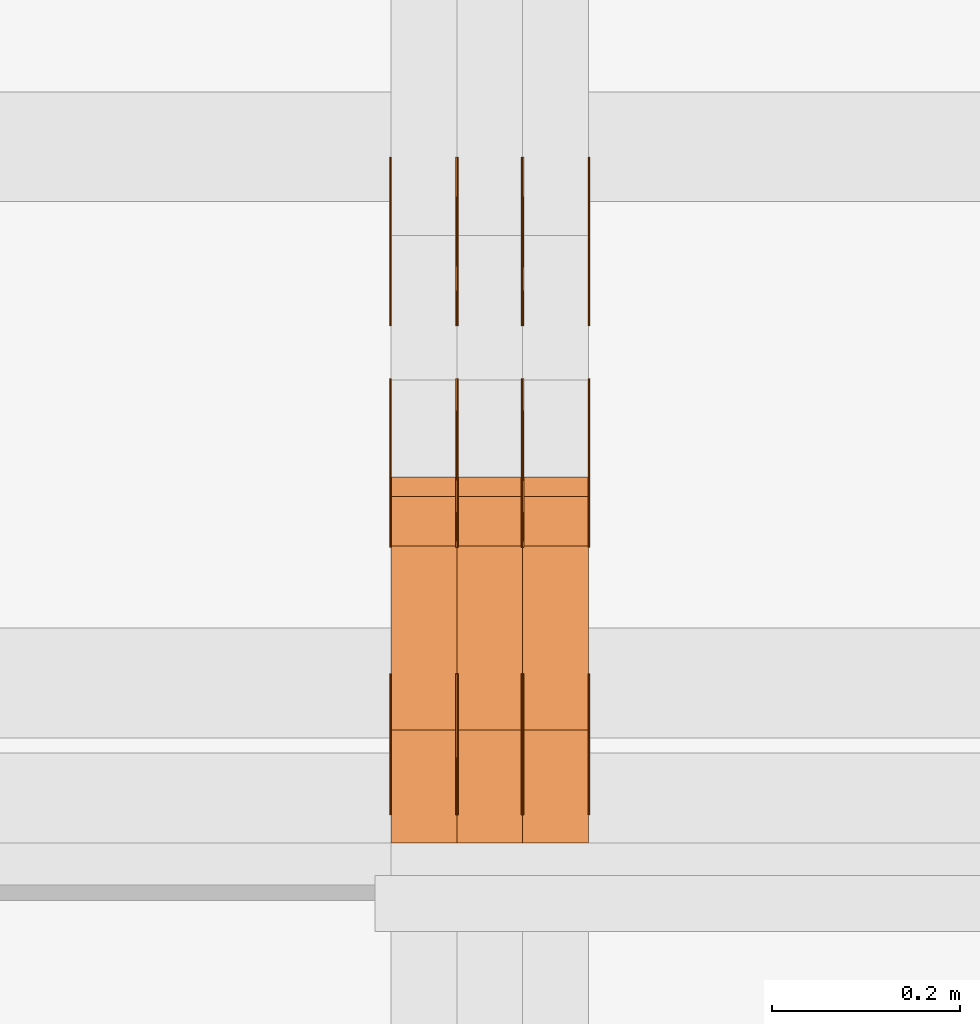
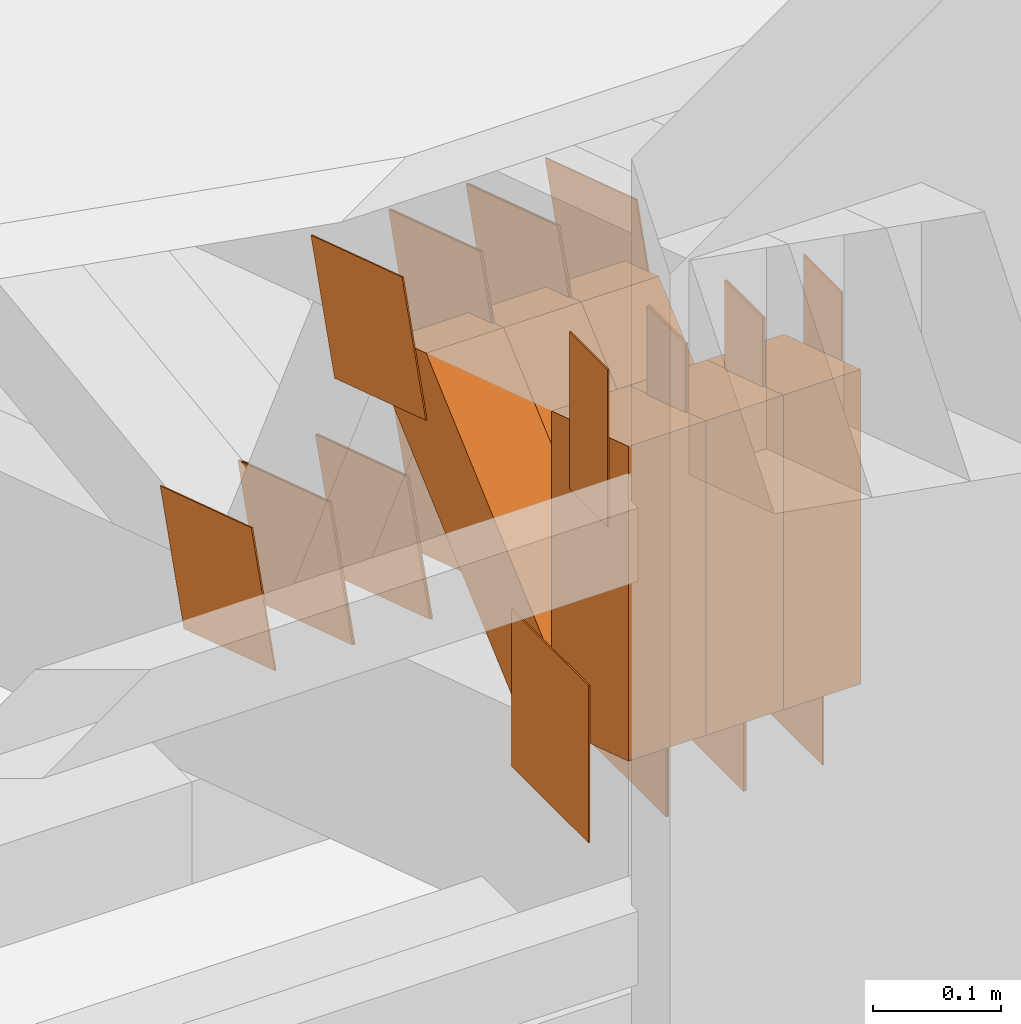
# One storey, part 99 of 385: 30 proxies.
"""IFC2X3 building model written with IfcOpenShell, lengths in millimetres."""

from ifc_helpers import new_model, entity, si_unit, converted_unit, derived_unit, direction, frame, origin, origin_2d_with_axis, place, context, subcontext, project, spatial, polyline, rectangle, outline, extrude, source, transform, mapped, material, type_object, type_shapes, element, save


model = new_model("IFC2X3")

# Units and contexts
model_context = context("Model", 3, precision=0.01, world=origin(), true_north=direction((6.12303176911189e-17, 1.0)))
body_context = subcontext(model_context, "Body", "Model", "MODEL_VIEW")
ifc_project = project(units=[si_unit("LENGTHUNIT", "METRE", prefix="MILLI"), si_unit("AREAUNIT", "SQUARE_METRE"), si_unit("VOLUMEUNIT", "CUBIC_METRE"), converted_unit("PLANEANGLEUNIT", "DEGREE", entity("IfcRatioMeasure", 0.0174532925199433), si_unit("PLANEANGLEUNIT", "RADIAN"), dimensions=[0, 0, 0, 0, 0, 0, 0]), si_unit("MASSUNIT", "GRAM", prefix="KILO"), derived_unit("MASSDENSITYUNIT", [(si_unit("MASSUNIT", "GRAM", prefix="KILO"), 1), (si_unit("LENGTHUNIT", "METRE"), -3)]), si_unit("TIMEUNIT", "SECOND"), si_unit("FREQUENCYUNIT", "HERTZ"), si_unit("THERMODYNAMICTEMPERATUREUNIT", "DEGREE_CELSIUS"), derived_unit("THERMALTRANSMITTANCEUNIT", [(si_unit("MASSUNIT", "GRAM", prefix="KILO"), 1), (si_unit("THERMODYNAMICTEMPERATUREUNIT", "KELVIN"), -1), (si_unit("TIMEUNIT", "SECOND"), -3)]), derived_unit("VOLUMETRICFLOWRATEUNIT", [(si_unit("LENGTHUNIT", "METRE"), 3), (si_unit("TIMEUNIT", "SECOND"), -1)]), si_unit("ELECTRICCURRENTUNIT", "AMPERE"), si_unit("ELECTRICVOLTAGEUNIT", "VOLT"), si_unit("POWERUNIT", "WATT"), si_unit("FORCEUNIT", "NEWTON", prefix="KILO"), si_unit("ILLUMINANCEUNIT", "LUX"), si_unit("LUMINOUSFLUXUNIT", "LUMEN"), si_unit("LUMINOUSINTENSITYUNIT", "CANDELA"), derived_unit("USERDEFINED", [(si_unit("MASSUNIT", "GRAM", prefix="KILO"), -1), (si_unit("LENGTHUNIT", "METRE"), -2), (si_unit("TIMEUNIT", "SECOND"), 3), (si_unit("LUMINOUSFLUXUNIT", "LUMEN"), 1)]), derived_unit("LINEARVELOCITYUNIT", [(si_unit("LENGTHUNIT", "METRE"), 1), (si_unit("TIMEUNIT", "SECOND"), -1)]), si_unit("PRESSUREUNIT", "PASCAL"), derived_unit("USERDEFINED", [(si_unit("LENGTHUNIT", "METRE"), -2), (si_unit("MASSUNIT", "GRAM", prefix="KILO"), 1), (si_unit("TIMEUNIT", "SECOND"), -2)])], contexts=[model_context])

# Site, building, storey
site_placement = place(None, origin())
site = spatial("IfcSite", under=ifc_project, at=site_placement, CompositionType="ELEMENT")
building_placement = place(site_placement, origin())
building = spatial("IfcBuilding", under=site, at=building_placement, CompositionType="ELEMENT")
storey_placement = place(building_placement, origin())
storey = spatial("IfcBuildingStorey", under=building, at=storey_placement, Name="Default", CompositionType="ELEMENT", Elevation=0.0)

# Proxies
ifc_material_1 = material(Name="IfcSurfaceStyle #136514")
building_element_proxy_type_1 = type_object("IfcBuildingElementProxyType", PredefinedType="NOTDEFINED", material=ifc_material_1)
shared_shape_1 = source(origin(), body_context, "Body", "SweptSolid", [
    extrude(rectangle(XDim=150.0, YDim=120.0, at=origin_2d_with_axis()), frame((75.0, 60.0, 0.0), z_axis=(0.0, 0.0, 1.0), x_axis=(-1.0, 0.0, 0.0)), (0.0, 0.0, 1.0), 1.3),
])
type_shapes(building_element_proxy_type_1, [shared_shape_1])
proxy_1_placement = place(building_placement, frame((9386.29999999998, 15840.0, 3652.70166015625), z_axis=(-1.0, 0.0, 0.0), x_axis=(0.0, 0.0, -1.0)))
element("IfcBuildingElementProxy", 1, at=proxy_1_placement, inside=storey, type_object=building_element_proxy_type_1, material=ifc_material_1, context=body_context, shape_type="MappedRepresentation", body=[
    mapped(shared_shape_1, transform((0.0, 0.0, 0.0), scale=1.0)),
])
ifc_material_2 = material(Name="IfcSurfaceStyle #136457")
building_element_proxy_type_2 = type_object("IfcBuildingElementProxyType", PredefinedType="NOTDEFINED", material=ifc_material_2)
shared_shape_2 = source(origin(), body_context, "Body", "SweptSolid", [
    extrude(rectangle(XDim=150.0, YDim=120.0, at=origin_2d_with_axis()), frame((75.0, 60.0, 0.0), z_axis=(0.0, 0.0, 1.0), x_axis=(-1.0, 0.0, 0.0)), (0.0, 0.0, 1.0), 1.3),
])
type_shapes(building_element_proxy_type_2, [shared_shape_2])
proxy_2_placement = place(building_placement, frame((9315.0, 15840.0, 3652.70166015625), z_axis=(-1.0, 0.0, 0.0), x_axis=(0.0, 0.0, -1.0)))
element("IfcBuildingElementProxy", 2, at=proxy_2_placement, inside=storey, type_object=building_element_proxy_type_2, material=ifc_material_2, context=body_context, shape_type="MappedRepresentation", body=[
    mapped(shared_shape_2, transform((0.0, 0.0, 0.0), scale=1.0)),
])
ifc_material_3 = material(Name="IfcSurfaceStyle #136400")
building_element_proxy_type_3 = type_object("IfcBuildingElementProxyType", PredefinedType="NOTDEFINED", material=ifc_material_3)
shared_shape_3 = source(origin(), body_context, "Body", "SweptSolid", [
    extrude(rectangle(XDim=150.0, YDim=120.0, at=origin_2d_with_axis()), frame((75.0, 60.0, 0.0), z_axis=(0.0, 0.0, 1.0), x_axis=(-1.0, 0.0, 0.0)), (0.0, 0.0, 1.0), 1.3),
])
type_shapes(building_element_proxy_type_3, [shared_shape_3])
proxy_3_placement = place(building_placement, frame((9316.29999999998, 15840.0, 3652.70166015625), z_axis=(-1.0, 0.0, 0.0), x_axis=(0.0, 0.0, -1.0)))
element("IfcBuildingElementProxy", 3, at=proxy_3_placement, inside=storey, type_object=building_element_proxy_type_3, material=ifc_material_3, context=body_context, shape_type="MappedRepresentation", body=[
    mapped(shared_shape_3, transform((0.0, 0.0, 0.0), scale=1.0)),
])
ifc_material_4 = material(Name="IfcSurfaceStyle #136343")
building_element_proxy_type_4 = type_object("IfcBuildingElementProxyType", PredefinedType="NOTDEFINED", material=ifc_material_4)
shared_shape_4 = source(origin(), body_context, "Body", "SweptSolid", [
    extrude(rectangle(XDim=150.0, YDim=120.0, at=origin_2d_with_axis()), frame((75.0, 60.0, 0.0), z_axis=(0.0, 0.0, 1.0), x_axis=(-1.0, 0.0, 0.0)), (0.0, 0.0, 1.0), 1.29999999999999),
])
type_shapes(building_element_proxy_type_4, [shared_shape_4])
proxy_4_placement = place(building_placement, frame((9245.0, 15840.0, 3652.70166015625), z_axis=(-1.0, 0.0, 0.0), x_axis=(0.0, 0.0, -1.0)))
element("IfcBuildingElementProxy", 4, at=proxy_4_placement, inside=storey, type_object=building_element_proxy_type_4, material=ifc_material_4, context=body_context, shape_type="MappedRepresentation", body=[
    mapped(shared_shape_4, transform((0.0, 0.0, 0.0), scale=1.0)),
])
ifc_material_5 = material(Name="IfcSurfaceStyle #136286")
building_element_proxy_type_5 = type_object("IfcBuildingElementProxyType", PredefinedType="NOTDEFINED", material=ifc_material_5)
shared_shape_5 = source(origin(), body_context, "Body", "SweptSolid", [
    extrude(rectangle(XDim=150.0, YDim=120.0, at=origin_2d_with_axis()), frame((75.0, 60.0, 0.0), z_axis=(0.0, 0.0, 1.0), x_axis=(-1.0, 0.0, 0.0)), (0.0, 0.0, 1.0), 1.29999999999999),
])
type_shapes(building_element_proxy_type_5, [shared_shape_5])
proxy_5_placement = place(building_placement, frame((9246.29999999998, 15840.0, 3652.70166015625), z_axis=(-1.0, 0.0, 0.0), x_axis=(0.0, 0.0, -1.0)))
element("IfcBuildingElementProxy", 5, at=proxy_5_placement, inside=storey, type_object=building_element_proxy_type_5, material=ifc_material_5, context=body_context, shape_type="MappedRepresentation", body=[
    mapped(shared_shape_5, transform((0.0, 0.0, 0.0), scale=1.0)),
])
ifc_material_6 = material(Name="IfcSurfaceStyle #136229")
building_element_proxy_type_6 = type_object("IfcBuildingElementProxyType", PredefinedType="NOTDEFINED", material=ifc_material_6)
shared_shape_6 = source(origin(), body_context, "Body", "SweptSolid", [
    extrude(rectangle(XDim=150.0, YDim=120.0, at=origin_2d_with_axis()), frame((75.0, 60.0, 0.0), z_axis=(0.0, 0.0, 1.0), x_axis=(-1.0, 0.0, 0.0)), (0.0, 0.0, 1.0), 1.29999999999999),
])
type_shapes(building_element_proxy_type_6, [shared_shape_6])
proxy_6_placement = place(building_placement, frame((9175.0, 15840.0, 3652.70166015625), z_axis=(-1.0, 0.0, 0.0), x_axis=(0.0, 0.0, -1.0)))
element("IfcBuildingElementProxy", 6, at=proxy_6_placement, inside=storey, type_object=building_element_proxy_type_6, material=ifc_material_6, context=body_context, shape_type="MappedRepresentation", body=[
    mapped(shared_shape_6, transform((0.0, 0.0, 0.0), scale=1.0)),
])
ifc_material_7 = material(Name="IfcSurfaceStyle #136172")
building_element_proxy_type_7 = type_object("IfcBuildingElementProxyType", PredefinedType="NOTDEFINED", material=ifc_material_7)
shared_shape_7 = source(origin(), body_context, "Body", "SweptSolid", [
    extrude(outline(polyline([(-74.9998605591118, -59.9999264677601), (74.9998754286171, -59.9999264677601), (74.9998605591118, 59.9999264677602), (-74.9998754286171, 59.9999264677602), (-74.9998605591118, -59.9999264677601)])), frame((74.9998754286171, 60.0000503992849, 0.0), z_axis=(0.0, 0.0, 1.0), x_axis=(-1.0, 0.0, 0.0)), (0.0, 0.0, 1.0), 1.3),
])
type_shapes(building_element_proxy_type_7, [shared_shape_7])
proxy_7_placement = place(building_placement, frame((9386.29999999998, 16352.8320303235, 3323.23212676408), z_axis=(-1.0, 0.0, 0.0), x_axis=(0.0, -0.951056516295124, 0.309016994375039)))
element("IfcBuildingElementProxy", 7, at=proxy_7_placement, inside=storey, type_object=building_element_proxy_type_7, material=ifc_material_7, context=body_context, shape_type="MappedRepresentation", body=[
    mapped(shared_shape_7, transform((0.0, 0.0, 0.0), scale=1.0)),
])
ifc_material_8 = material(Name="IfcSurfaceStyle #136115")
building_element_proxy_type_8 = type_object("IfcBuildingElementProxyType", PredefinedType="NOTDEFINED", material=ifc_material_8)
shared_shape_8 = source(origin(), body_context, "Body", "SweptSolid", [
    extrude(outline(polyline([(-74.9998605591118, -59.9999264677601), (74.9998754286171, -59.9999264677601), (74.9998605591118, 59.9999264677602), (-74.9998754286171, 59.9999264677602), (-74.9998605591118, -59.9999264677601)])), frame((74.9998754286171, 60.0000503992849, 0.0), z_axis=(0.0, 0.0, 1.0), x_axis=(-1.0, 0.0, 0.0)), (0.0, 0.0, 1.0), 1.3),
])
type_shapes(building_element_proxy_type_8, [shared_shape_8])
proxy_8_placement = place(building_placement, frame((9315.0, 16352.8320303235, 3323.23212676408), z_axis=(-1.0, 0.0, 0.0), x_axis=(0.0, -0.951056516295124, 0.309016994375039)))
element("IfcBuildingElementProxy", 8, at=proxy_8_placement, inside=storey, type_object=building_element_proxy_type_8, material=ifc_material_8, context=body_context, shape_type="MappedRepresentation", body=[
    mapped(shared_shape_8, transform((0.0, 0.0, 0.0), scale=1.0)),
])
ifc_material_9 = material(Name="IfcSurfaceStyle #136058")
building_element_proxy_type_9 = type_object("IfcBuildingElementProxyType", PredefinedType="NOTDEFINED", material=ifc_material_9)
shared_shape_9 = source(origin(), body_context, "Body", "SweptSolid", [
    extrude(outline(polyline([(-74.9998605591118, -59.9999264677601), (74.9998754286171, -59.9999264677601), (74.9998605591118, 59.9999264677602), (-74.9998754286171, 59.9999264677602), (-74.9998605591118, -59.9999264677601)])), frame((74.9998754286171, 60.0000503992849, 0.0), z_axis=(0.0, 0.0, 1.0), x_axis=(-1.0, 0.0, 0.0)), (0.0, 0.0, 1.0), 1.3),
])
type_shapes(building_element_proxy_type_9, [shared_shape_9])
proxy_9_placement = place(building_placement, frame((9316.29999999998, 16352.8320303235, 3323.23212676408), z_axis=(-1.0, 0.0, 0.0), x_axis=(0.0, -0.951056516295124, 0.309016994375039)))
element("IfcBuildingElementProxy", 9, at=proxy_9_placement, inside=storey, type_object=building_element_proxy_type_9, material=ifc_material_9, context=body_context, shape_type="MappedRepresentation", body=[
    mapped(shared_shape_9, transform((0.0, 0.0, 0.0), scale=1.0)),
])
ifc_material_10 = material(Name="IfcSurfaceStyle #136001")
building_element_proxy_type_10 = type_object("IfcBuildingElementProxyType", PredefinedType="NOTDEFINED", material=ifc_material_10)
shared_shape_10 = source(origin(), body_context, "Body", "SweptSolid", [
    extrude(outline(polyline([(-74.9998605591118, -59.9999264677601), (74.9998754286171, -59.9999264677601), (74.9998605591118, 59.9999264677602), (-74.9998754286171, 59.9999264677602), (-74.9998605591118, -59.9999264677601)])), frame((74.9998754286171, 60.0000503992849, 0.0), z_axis=(0.0, 0.0, 1.0), x_axis=(-1.0, 0.0, 0.0)), (0.0, 0.0, 1.0), 1.29999999999999),
])
type_shapes(building_element_proxy_type_10, [shared_shape_10])
proxy_10_placement = place(building_placement, frame((9245.0, 16352.8320303235, 3323.23212676408), z_axis=(-1.0, 0.0, 0.0), x_axis=(0.0, -0.951056516295124, 0.309016994375039)))
element("IfcBuildingElementProxy", 10, at=proxy_10_placement, inside=storey, type_object=building_element_proxy_type_10, material=ifc_material_10, context=body_context, shape_type="MappedRepresentation", body=[
    mapped(shared_shape_10, transform((0.0, 0.0, 0.0), scale=1.0)),
])
ifc_material_11 = material(Name="IfcSurfaceStyle #135944")
building_element_proxy_type_11 = type_object("IfcBuildingElementProxyType", PredefinedType="NOTDEFINED", material=ifc_material_11)
shared_shape_11 = source(origin(), body_context, "Body", "SweptSolid", [
    extrude(outline(polyline([(-74.9998605591118, -59.9999264677601), (74.9998754286171, -59.9999264677601), (74.9998605591118, 59.9999264677602), (-74.9998754286171, 59.9999264677602), (-74.9998605591118, -59.9999264677601)])), frame((74.9998754286171, 60.0000503992849, 0.0), z_axis=(0.0, 0.0, 1.0), x_axis=(-1.0, 0.0, 0.0)), (0.0, 0.0, 1.0), 1.29999999999999),
])
type_shapes(building_element_proxy_type_11, [shared_shape_11])
proxy_11_placement = place(building_placement, frame((9246.29999999998, 16352.8320303235, 3323.23212676408), z_axis=(-1.0, 0.0, 0.0), x_axis=(0.0, -0.951056516295124, 0.309016994375039)))
element("IfcBuildingElementProxy", 11, at=proxy_11_placement, inside=storey, type_object=building_element_proxy_type_11, material=ifc_material_11, context=body_context, shape_type="MappedRepresentation", body=[
    mapped(shared_shape_11, transform((0.0, 0.0, 0.0), scale=1.0)),
])
ifc_material_12 = material(Name="IfcSurfaceStyle #135887")
building_element_proxy_type_12 = type_object("IfcBuildingElementProxyType", PredefinedType="NOTDEFINED", material=ifc_material_12)
shared_shape_12 = source(origin(), body_context, "Body", "SweptSolid", [
    extrude(outline(polyline([(-74.9998605591118, -59.9999264677601), (74.9998754286171, -59.9999264677601), (74.9998605591118, 59.9999264677602), (-74.9998754286171, 59.9999264677602), (-74.9998605591118, -59.9999264677601)])), frame((74.9998754286171, 60.0000503992849, 0.0), z_axis=(0.0, 0.0, 1.0), x_axis=(-1.0, 0.0, 0.0)), (0.0, 0.0, 1.0), 1.29999999999999),
])
type_shapes(building_element_proxy_type_12, [shared_shape_12])
proxy_12_placement = place(building_placement, frame((9175.0, 16352.8320303235, 3323.23212676408), z_axis=(-1.0, 0.0, 0.0), x_axis=(0.0, -0.951056516295124, 0.309016994375039)))
element("IfcBuildingElementProxy", 12, at=proxy_12_placement, inside=storey, type_object=building_element_proxy_type_12, material=ifc_material_12, context=body_context, shape_type="MappedRepresentation", body=[
    mapped(shared_shape_12, transform((0.0, 0.0, 0.0), scale=1.0)),
])
ifc_material_13 = material(Name="IfcSurfaceStyle #131726")
building_element_proxy_type_13 = type_object("IfcBuildingElementProxyType", PredefinedType="NOTDEFINED", material=ifc_material_13)
shared_shape_13 = source(origin(), body_context, "Body", "SweptSolid", [
    extrude(outline(polyline([(-75.0003249421702, -60.0000773549573), (75.0003398116874, -60.0000773549573), (75.0003249421711, 60.0000773549573), (-75.0003398116883, 60.0000773549573), (-75.0003249421702, -60.0000773549573)])), frame((75.0003398116874, 60.0000773549573, 0.0), z_axis=(0.0, 0.0, 1.0), x_axis=(-1.0, 0.0, 0.0)), (0.0, 0.0, 1.0), 1.3),
])
type_shapes(building_element_proxy_type_13, [shared_shape_13])
proxy_13_placement = place(building_placement, frame((9386.29999999998, 16117.0849050545, 3705.49074668796), z_axis=(-1.0, 0.0, 0.0), x_axis=(0.0, -0.951056516295154, 0.309016994374948)))
element("IfcBuildingElementProxy", 13, at=proxy_13_placement, inside=storey, type_object=building_element_proxy_type_13, material=ifc_material_13, context=body_context, shape_type="MappedRepresentation", body=[
    mapped(shared_shape_13, transform((0.0, 0.0, 0.0), scale=1.0)),
])
ifc_material_14 = material(Name="IfcSurfaceStyle #131669")
building_element_proxy_type_14 = type_object("IfcBuildingElementProxyType", PredefinedType="NOTDEFINED", material=ifc_material_14)
shared_shape_14 = source(origin(), body_context, "Body", "SweptSolid", [
    extrude(outline(polyline([(-75.0003249421702, -60.0000773549573), (75.0003398116874, -60.0000773549573), (75.0003249421711, 60.0000773549573), (-75.0003398116883, 60.0000773549573), (-75.0003249421702, -60.0000773549573)])), frame((75.0003398116874, 60.0000773549573, 0.0), z_axis=(0.0, 0.0, 1.0), x_axis=(-1.0, 0.0, 0.0)), (0.0, 0.0, 1.0), 1.3),
])
type_shapes(building_element_proxy_type_14, [shared_shape_14])
proxy_14_placement = place(building_placement, frame((9315.0, 16117.0849050545, 3705.49074668796), z_axis=(-1.0, 0.0, 0.0), x_axis=(0.0, -0.951056516295154, 0.309016994374948)))
element("IfcBuildingElementProxy", 14, at=proxy_14_placement, inside=storey, type_object=building_element_proxy_type_14, material=ifc_material_14, context=body_context, shape_type="MappedRepresentation", body=[
    mapped(shared_shape_14, transform((0.0, 0.0, 0.0), scale=1.0)),
])
ifc_material_15 = material(Name="IfcSurfaceStyle #131612")
building_element_proxy_type_15 = type_object("IfcBuildingElementProxyType", PredefinedType="NOTDEFINED", material=ifc_material_15)
shared_shape_15 = source(origin(), body_context, "Body", "SweptSolid", [
    extrude(outline(polyline([(-75.0003249421702, -60.0000773549573), (75.0003398116874, -60.0000773549573), (75.0003249421711, 60.0000773549573), (-75.0003398116883, 60.0000773549573), (-75.0003249421702, -60.0000773549573)])), frame((75.0003398116874, 60.0000773549573, 0.0), z_axis=(0.0, 0.0, 1.0), x_axis=(-1.0, 0.0, 0.0)), (0.0, 0.0, 1.0), 1.3),
])
type_shapes(building_element_proxy_type_15, [shared_shape_15])
proxy_15_placement = place(building_placement, frame((9316.29999999998, 16117.0849050545, 3705.49074668796), z_axis=(-1.0, 0.0, 0.0), x_axis=(0.0, -0.951056516295154, 0.309016994374948)))
element("IfcBuildingElementProxy", 15, at=proxy_15_placement, inside=storey, type_object=building_element_proxy_type_15, material=ifc_material_15, context=body_context, shape_type="MappedRepresentation", body=[
    mapped(shared_shape_15, transform((0.0, 0.0, 0.0), scale=1.0)),
])
ifc_material_16 = material(Name="IfcSurfaceStyle #131555")
building_element_proxy_type_16 = type_object("IfcBuildingElementProxyType", PredefinedType="NOTDEFINED", material=ifc_material_16)
shared_shape_16 = source(origin(), body_context, "Body", "SweptSolid", [
    extrude(outline(polyline([(-75.0003249421702, -60.0000773549573), (75.0003398116874, -60.0000773549573), (75.0003249421711, 60.0000773549573), (-75.0003398116883, 60.0000773549573), (-75.0003249421702, -60.0000773549573)])), frame((75.0003398116874, 60.0000773549573, 0.0), z_axis=(0.0, 0.0, 1.0), x_axis=(-1.0, 0.0, 0.0)), (0.0, 0.0, 1.0), 1.29999999999999),
])
type_shapes(building_element_proxy_type_16, [shared_shape_16])
proxy_16_placement = place(building_placement, frame((9245.0, 16117.0849050545, 3705.49074668796), z_axis=(-1.0, 0.0, 0.0), x_axis=(0.0, -0.951056516295154, 0.309016994374948)))
element("IfcBuildingElementProxy", 16, at=proxy_16_placement, inside=storey, type_object=building_element_proxy_type_16, material=ifc_material_16, context=body_context, shape_type="MappedRepresentation", body=[
    mapped(shared_shape_16, transform((0.0, 0.0, 0.0), scale=1.0)),
])
ifc_material_17 = material(Name="IfcSurfaceStyle #131498")
building_element_proxy_type_17 = type_object("IfcBuildingElementProxyType", PredefinedType="NOTDEFINED", material=ifc_material_17)
shared_shape_17 = source(origin(), body_context, "Body", "SweptSolid", [
    extrude(outline(polyline([(-75.0003249421702, -60.0000773549573), (75.0003398116874, -60.0000773549573), (75.0003249421711, 60.0000773549573), (-75.0003398116883, 60.0000773549573), (-75.0003249421702, -60.0000773549573)])), frame((75.0003398116874, 60.0000773549573, 0.0), z_axis=(0.0, 0.0, 1.0), x_axis=(-1.0, 0.0, 0.0)), (0.0, 0.0, 1.0), 1.29999999999999),
])
type_shapes(building_element_proxy_type_17, [shared_shape_17])
proxy_17_placement = place(building_placement, frame((9246.29999999998, 16117.0849050545, 3705.49074668796), z_axis=(-1.0, 0.0, 0.0), x_axis=(0.0, -0.951056516295154, 0.309016994374948)))
element("IfcBuildingElementProxy", 17, at=proxy_17_placement, inside=storey, type_object=building_element_proxy_type_17, material=ifc_material_17, context=body_context, shape_type="MappedRepresentation", body=[
    mapped(shared_shape_17, transform((0.0, 0.0, 0.0), scale=1.0)),
])
ifc_material_18 = material(Name="IfcSurfaceStyle #131441")
building_element_proxy_type_18 = type_object("IfcBuildingElementProxyType", PredefinedType="NOTDEFINED", material=ifc_material_18)
shared_shape_18 = source(origin(), body_context, "Body", "SweptSolid", [
    extrude(outline(polyline([(-75.0003249421702, -60.0000773549573), (75.0003398116874, -60.0000773549573), (75.0003249421711, 60.0000773549573), (-75.0003398116883, 60.0000773549573), (-75.0003249421702, -60.0000773549573)])), frame((75.0003398116874, 60.0000773549573, 0.0), z_axis=(0.0, 0.0, 1.0), x_axis=(-1.0, 0.0, 0.0)), (0.0, 0.0, 1.0), 1.29999999999999),
])
type_shapes(building_element_proxy_type_18, [shared_shape_18])
proxy_18_placement = place(building_placement, frame((9175.0, 16117.0849050545, 3705.49074668796), z_axis=(-1.0, 0.0, 0.0), x_axis=(0.0, -0.951056516295154, 0.309016994374948)))
element("IfcBuildingElementProxy", 18, at=proxy_18_placement, inside=storey, type_object=building_element_proxy_type_18, material=ifc_material_18, context=body_context, shape_type="MappedRepresentation", body=[
    mapped(shared_shape_18, transform((0.0, 0.0, 0.0), scale=1.0)),
])
ifc_material_19 = material(Name="IfcSurfaceStyle #131042")
building_element_proxy_type_19 = type_object("IfcBuildingElementProxyType", PredefinedType="NOTDEFINED", material=ifc_material_19)
shared_shape_19 = source(origin(), body_context, "Body", "SweptSolid", [
    extrude(rectangle(XDim=150.0, YDim=60.0, at=origin_2d_with_axis()), frame((75.0000705696311, 30.0, 0.0), z_axis=(0.0, 0.0, 1.0), x_axis=(-1.0, 0.0, 0.0)), (0.0, 0.0, 1.0), 1.3),
])
type_shapes(building_element_proxy_type_19, [shared_shape_19])
proxy_19_placement = place(building_placement, frame((9386.29999999998, 15750.0, 3972.59919166338), z_axis=(-1.0, 0.0, 0.0), x_axis=(0.0, 0.0, -1.0)))
element("IfcBuildingElementProxy", 19, at=proxy_19_placement, inside=storey, type_object=building_element_proxy_type_19, material=ifc_material_19, context=body_context, shape_type="MappedRepresentation", body=[
    mapped(shared_shape_19, transform((0.0, 0.0, 0.0), scale=1.0)),
])
ifc_material_20 = material(Name="IfcSurfaceStyle #130985")
building_element_proxy_type_20 = type_object("IfcBuildingElementProxyType", PredefinedType="NOTDEFINED", material=ifc_material_20)
shared_shape_20 = source(origin(), body_context, "Body", "SweptSolid", [
    extrude(rectangle(XDim=150.0, YDim=60.0, at=origin_2d_with_axis()), frame((75.0000705696311, 30.0, 0.0), z_axis=(0.0, 0.0, 1.0), x_axis=(-1.0, 0.0, 0.0)), (0.0, 0.0, 1.0), 1.3),
])
type_shapes(building_element_proxy_type_20, [shared_shape_20])
proxy_20_placement = place(building_placement, frame((9315.0, 15750.0, 3972.59919166338), z_axis=(-1.0, 0.0, 0.0), x_axis=(0.0, 0.0, -1.0)))
element("IfcBuildingElementProxy", 20, at=proxy_20_placement, inside=storey, type_object=building_element_proxy_type_20, material=ifc_material_20, context=body_context, shape_type="MappedRepresentation", body=[
    mapped(shared_shape_20, transform((0.0, 0.0, 0.0), scale=1.0)),
])
ifc_material_21 = material(Name="IfcSurfaceStyle #130928")
building_element_proxy_type_21 = type_object("IfcBuildingElementProxyType", PredefinedType="NOTDEFINED", material=ifc_material_21)
shared_shape_21 = source(origin(), body_context, "Body", "SweptSolid", [
    extrude(rectangle(XDim=150.0, YDim=60.0, at=origin_2d_with_axis()), frame((75.0000705696311, 30.0, 0.0), z_axis=(0.0, 0.0, 1.0), x_axis=(-1.0, 0.0, 0.0)), (0.0, 0.0, 1.0), 1.3),
])
type_shapes(building_element_proxy_type_21, [shared_shape_21])
proxy_21_placement = place(building_placement, frame((9316.29999999998, 15750.0, 3972.59919166338), z_axis=(-1.0, 0.0, 0.0), x_axis=(0.0, 0.0, -1.0)))
element("IfcBuildingElementProxy", 21, at=proxy_21_placement, inside=storey, type_object=building_element_proxy_type_21, material=ifc_material_21, context=body_context, shape_type="MappedRepresentation", body=[
    mapped(shared_shape_21, transform((0.0, 0.0, 0.0), scale=1.0)),
])
ifc_material_22 = material(Name="IfcSurfaceStyle #130871")
building_element_proxy_type_22 = type_object("IfcBuildingElementProxyType", PredefinedType="NOTDEFINED", material=ifc_material_22)
shared_shape_22 = source(origin(), body_context, "Body", "SweptSolid", [
    extrude(rectangle(XDim=150.0, YDim=60.0, at=origin_2d_with_axis()), frame((75.0000705696311, 30.0, 0.0), z_axis=(0.0, 0.0, 1.0), x_axis=(-1.0, 0.0, 0.0)), (0.0, 0.0, 1.0), 1.29999999999999),
])
type_shapes(building_element_proxy_type_22, [shared_shape_22])
proxy_22_placement = place(building_placement, frame((9245.0, 15750.0, 3972.59919166338), z_axis=(-1.0, 0.0, 0.0), x_axis=(0.0, 0.0, -1.0)))
element("IfcBuildingElementProxy", 22, at=proxy_22_placement, inside=storey, type_object=building_element_proxy_type_22, material=ifc_material_22, context=body_context, shape_type="MappedRepresentation", body=[
    mapped(shared_shape_22, transform((0.0, 0.0, 0.0), scale=1.0)),
])
ifc_material_23 = material(Name="IfcSurfaceStyle #130814")
building_element_proxy_type_23 = type_object("IfcBuildingElementProxyType", PredefinedType="NOTDEFINED", material=ifc_material_23)
shared_shape_23 = source(origin(), body_context, "Body", "SweptSolid", [
    extrude(rectangle(XDim=150.0, YDim=60.0, at=origin_2d_with_axis()), frame((75.0000705696311, 30.0, 0.0), z_axis=(0.0, 0.0, 1.0), x_axis=(-1.0, 0.0, 0.0)), (0.0, 0.0, 1.0), 1.29999999999999),
])
type_shapes(building_element_proxy_type_23, [shared_shape_23])
proxy_23_placement = place(building_placement, frame((9246.29999999998, 15750.0, 3972.59919166338), z_axis=(-1.0, 0.0, 0.0), x_axis=(0.0, 0.0, -1.0)))
element("IfcBuildingElementProxy", 23, at=proxy_23_placement, inside=storey, type_object=building_element_proxy_type_23, material=ifc_material_23, context=body_context, shape_type="MappedRepresentation", body=[
    mapped(shared_shape_23, transform((0.0, 0.0, 0.0), scale=1.0)),
])
ifc_material_24 = material(Name="IfcSurfaceStyle #130757")
building_element_proxy_type_24 = type_object("IfcBuildingElementProxyType", PredefinedType="NOTDEFINED", material=ifc_material_24)
shared_shape_24 = source(origin(), body_context, "Body", "SweptSolid", [
    extrude(rectangle(XDim=150.0, YDim=60.0, at=origin_2d_with_axis()), frame((75.0000705696311, 30.0, 0.0), z_axis=(0.0, 0.0, 1.0), x_axis=(-1.0, 0.0, 0.0)), (0.0, 0.0, 1.0), 1.29999999999999),
])
type_shapes(building_element_proxy_type_24, [shared_shape_24])
proxy_24_placement = place(building_placement, frame((9175.0, 15750.0, 3972.59919166338), z_axis=(-1.0, 0.0, 0.0), x_axis=(0.0, 0.0, -1.0)))
element("IfcBuildingElementProxy", 24, at=proxy_24_placement, inside=storey, type_object=building_element_proxy_type_24, material=ifc_material_24, context=body_context, shape_type="MappedRepresentation", body=[
    mapped(shared_shape_24, transform((0.0, 0.0, 0.0), scale=1.0)),
])
ifc_material_25 = material(Name="IfcSurfaceStyle #121673")
building_element_proxy_type_25 = type_object("IfcBuildingElementProxyType", Name="T1-W50 121671", PredefinedType="NOTDEFINED", material=ifc_material_25)
shared_shape_25 = source(origin(), body_context, "Body", "SweptSolid", [
    extrude(outline(polyline([(-128.56619634284, -47.4999385885712), (133.151257249084, -47.4999385885712), (161.172800006526, -0.000129729183733609), (147.291467726413, 47.500068317755), (-142.513973767368, 47.500068317755), (-170.535354871815, -0.000129729183754689), (-128.56619634284, -47.4999385885712)])), frame((161.17310141218, 47.5001898716564, 0.0), z_axis=(0.0, 0.0, 1.0), x_axis=(-1.0, 0.0, 0.0)), (0.0, 0.0, 1.0), 70.0),
])
type_shapes(building_element_proxy_type_25, [shared_shape_25])
proxy_25_placement = place(building_placement, frame((9385.0, 16060.0297689714, 3761.73994820667), z_axis=(-1.0, 0.0, 0.0), x_axis=(0.0, -0.749388407538668, -0.662130662820156)))
element("IfcBuildingElementProxy", 25, at=proxy_25_placement, inside=storey, type_object=building_element_proxy_type_25, material=ifc_material_25, Name="T1-W50", context=body_context, shape_type="MappedRepresentation", body=[
    mapped(shared_shape_25, transform((0.0, 0.0, 0.0), scale=1.0)),
])
ifc_material_26 = material(Name="IfcSurfaceStyle #121598")
building_element_proxy_type_26 = type_object("IfcBuildingElementProxyType", Name="T1-W50 121596", PredefinedType="NOTDEFINED", material=ifc_material_26)
shared_shape_26 = source(origin(), body_context, "Body", "SweptSolid", [
    extrude(outline(polyline([(-128.56619634284, -47.4999385885712), (133.151257249084, -47.4999385885712), (161.172800006526, -0.000129729183733609), (147.291467726413, 47.500068317755), (-142.513973767368, 47.500068317755), (-170.535354871815, -0.000129729183754689), (-128.56619634284, -47.4999385885712)])), frame((161.17310141218, 47.5001898716564, 0.0), z_axis=(0.0, 0.0, 1.0), x_axis=(-1.0, 0.0, 0.0)), (0.0, 0.0, 1.0), 70.0),
])
type_shapes(building_element_proxy_type_26, [shared_shape_26])
proxy_26_placement = place(building_placement, frame((9315.0, 16060.0297689714, 3761.73994820667), z_axis=(-1.0, 0.0, 0.0), x_axis=(0.0, -0.749388407538668, -0.662130662820156)))
element("IfcBuildingElementProxy", 26, at=proxy_26_placement, inside=storey, type_object=building_element_proxy_type_26, material=ifc_material_26, Name="T1-W50", context=body_context, shape_type="MappedRepresentation", body=[
    mapped(shared_shape_26, transform((0.0, 0.0, 0.0), scale=1.0)),
])
ifc_material_27 = material(Name="IfcSurfaceStyle #121523")
building_element_proxy_type_27 = type_object("IfcBuildingElementProxyType", Name="T1-W50 121521", PredefinedType="NOTDEFINED", material=ifc_material_27)
shared_shape_27 = source(origin(), body_context, "Body", "SweptSolid", [
    extrude(outline(polyline([(-128.56619634284, -47.4999385885712), (133.151257249084, -47.4999385885712), (161.172800006526, -0.000129729183733609), (147.291467726413, 47.500068317755), (-142.513973767368, 47.500068317755), (-170.535354871815, -0.000129729183754689), (-128.56619634284, -47.4999385885712)])), frame((161.17310141218, 47.5001898716564, 0.0), z_axis=(0.0, 0.0, 1.0), x_axis=(-1.0, 0.0, 0.0)), (0.0, 0.0, 1.0), 70.0),
])
type_shapes(building_element_proxy_type_27, [shared_shape_27])
proxy_27_placement = place(building_placement, frame((9245.0, 16060.0297689714, 3761.73994820667), z_axis=(-1.0, 0.0, 0.0), x_axis=(0.0, -0.749388407538668, -0.662130662820156)))
element("IfcBuildingElementProxy", 27, at=proxy_27_placement, inside=storey, type_object=building_element_proxy_type_27, material=ifc_material_27, Name="T1-W50", context=body_context, shape_type="MappedRepresentation", body=[
    mapped(shared_shape_27, transform((0.0, 0.0, 0.0), scale=1.0)),
])
ifc_material_28 = material(Name="IfcSurfaceStyle #121277")
building_element_proxy_type_28 = type_object("IfcBuildingElementProxyType", Name="T1-W2 121275", PredefinedType="NOTDEFINED", material=ifc_material_28)
shared_shape_28 = source(origin(), body_context, "Body", "SweptSolid", [
    extrude(outline(polyline([(-130.705993652344, -60.0), (169.696350097656, -60.0), (130.706115722656, 60.0), (-169.696472167969, 60.0), (-130.705993652344, -60.0)])), frame((169.696429629256, 60.0, 0.0), z_axis=(0.0, 0.0, 1.0), x_axis=(-1.0, 0.0, 0.0)), (0.0, 0.0, 1.0), 70.0),
])
type_shapes(building_element_proxy_type_28, [shared_shape_28])
proxy_28_placement = place(building_placement, frame((9385.0, 15660.0, 3577.70158062465), z_axis=(-1.0, 0.0, 0.0), x_axis=(0.0, 0.0, 1.0)))
element("IfcBuildingElementProxy", 28, at=proxy_28_placement, inside=storey, type_object=building_element_proxy_type_28, material=ifc_material_28, Name="T1-W2", context=body_context, shape_type="MappedRepresentation", body=[
    mapped(shared_shape_28, transform((0.0, 0.0, 0.0), scale=1.0)),
])
ifc_material_29 = material(Name="IfcSurfaceStyle #121220")
building_element_proxy_type_29 = type_object("IfcBuildingElementProxyType", Name="T1-W2 121218", PredefinedType="NOTDEFINED", material=ifc_material_29)
shared_shape_29 = source(origin(), body_context, "Body", "SweptSolid", [
    extrude(outline(polyline([(-130.705993652344, -60.0), (169.696350097656, -60.0), (130.706115722656, 60.0), (-169.696472167969, 60.0), (-130.705993652344, -60.0)])), frame((169.696429629256, 60.0, 0.0), z_axis=(0.0, 0.0, 1.0), x_axis=(-1.0, 0.0, 0.0)), (0.0, 0.0, 1.0), 70.0),
])
type_shapes(building_element_proxy_type_29, [shared_shape_29])
proxy_29_placement = place(building_placement, frame((9315.0, 15660.0, 3577.70158062465), z_axis=(-1.0, 0.0, 0.0), x_axis=(0.0, 0.0, 1.0)))
element("IfcBuildingElementProxy", 29, at=proxy_29_placement, inside=storey, type_object=building_element_proxy_type_29, material=ifc_material_29, Name="T1-W2", context=body_context, shape_type="MappedRepresentation", body=[
    mapped(shared_shape_29, transform((0.0, 0.0, 0.0), scale=1.0)),
])
ifc_material_30 = material(Name="IfcSurfaceStyle #121163")
building_element_proxy_type_30 = type_object("IfcBuildingElementProxyType", Name="T1-W2 121161", PredefinedType="NOTDEFINED", material=ifc_material_30)
shared_shape_30 = source(origin(), body_context, "Body", "SweptSolid", [
    extrude(outline(polyline([(-130.705993652344, -60.0), (169.696350097656, -60.0), (130.706115722656, 60.0), (-169.696472167969, 60.0), (-130.705993652344, -60.0)])), frame((169.696429629256, 60.0, 0.0), z_axis=(0.0, 0.0, 1.0), x_axis=(-1.0, 0.0, 0.0)), (0.0, 0.0, 1.0), 70.0),
])
type_shapes(building_element_proxy_type_30, [shared_shape_30])
proxy_30_placement = place(building_placement, frame((9245.0, 15660.0, 3577.70158062465), z_axis=(-1.0, 0.0, 0.0), x_axis=(0.0, 0.0, 1.0)))
element("IfcBuildingElementProxy", 30, at=proxy_30_placement, inside=storey, type_object=building_element_proxy_type_30, material=ifc_material_30, Name="T1-W2", context=body_context, shape_type="MappedRepresentation", body=[
    mapped(shared_shape_30, transform((0.0, 0.0, 0.0), scale=1.0)),
])

save(model, "model.ifc")
